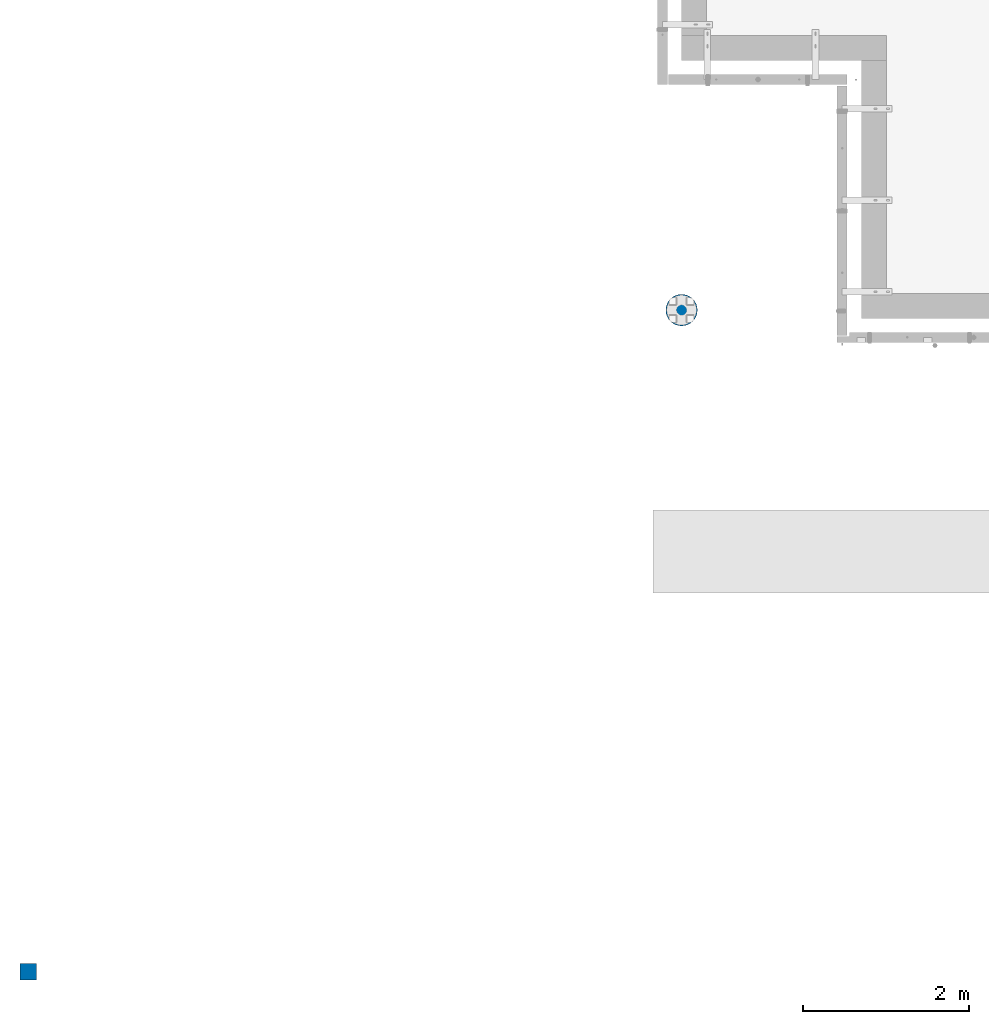
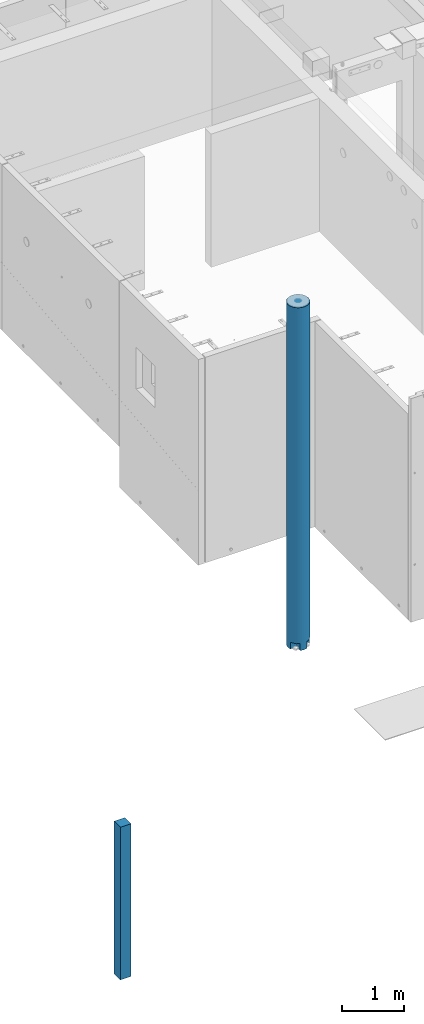
# One storey, part 1 of 264: 2 columns, 2 elements without a shape of their own.
"""IFC2X3 building model written with IfcOpenShell, lengths in millimetres."""

import ifcopenshell
import ifcopenshell.guid

model = None  # the IFC model being written
_history = None  # IfcOwnerHistory: only IFC2X3 demands one
_inside = {}  # id of a spatial element -> (the spatial element, [elements in it])
_under = {}  # id of a project, library or spatial element -> (it, [spatial elements below it])
_declared = {}  # id of a project -> (the project, [libraries it declares])
_typed = {}  # id of a type object -> (the type object, [elements of that type])
_made_of = {}  # id of a material, layer set ... -> (it, [elements and type objects made of it])


def new_model(schema):
    """Start an empty IFC model of exactly this schema.

    Asked for "IFC4X3", IfcOpenShell would pick the latest addendum, in which some entities
    have other attributes; the version numbers below select the first issue.
    IFC2X3 requires an IfcOwnerHistory on every rooted entity: one is made here for all.
    """
    global model, _history
    if schema == "IFC4X3":
        model = ifcopenshell.file(schema_version=(4, 3, 0, 0))
    else:
        model = ifcopenshell.file(schema=schema)
    _inside.clear()
    _under.clear()
    _declared.clear()
    _typed.clear()
    _made_of.clear()
    _history = None
    if model.schema == "IFC2X3":
        org = make("IfcOrganization", Name="unknown")
        user = make(
            "IfcPersonAndOrganization",
            ThePerson=make("IfcPerson", FamilyName="unknown"),
            TheOrganization=org,
        )
        app = make(
            "IfcApplication",
            ApplicationDeveloper=org,
            Version="unknown",
            ApplicationFullName="unknown",
            ApplicationIdentifier="unknown",
        )
        _history = make(
            "IfcOwnerHistory",
            OwningUser=user,
            OwningApplication=app,
            ChangeAction="ADDED",
            CreationDate=0,
        )
    return model


def make(cls, **values):
    """One entity of the class cls with the attributes given. An attribute that is None is left unset."""
    return model.create_entity(
        cls, **{name: value for name, value in values.items() if value is not None}
    )


def rooted(cls, **values):
    """An entity with a GlobalId (a new one), such as an element, a storey or a relation."""
    return make(cls, GlobalId=ifcopenshell.guid.new(), OwnerHistory=_history, **values)


def si_unit(unit_type, name, prefix=None):
    """IfcSIUnit, for example si_unit("LENGTHUNIT", "METRE", prefix="MILLI")."""
    return make("IfcSIUnit", UnitType=unit_type, Prefix=prefix, Name=name)


def assignment(units):
    """IfcUnitAssignment: the units of a project."""
    return None if units is None else make("IfcUnitAssignment", Units=units)


def point(xyz):
    """IfcCartesianPoint."""
    return None if xyz is None else make("IfcCartesianPoint", Coordinates=xyz)


def direction(xyz):
    """IfcDirection."""
    return None if xyz is None else make("IfcDirection", DirectionRatios=xyz)


def frame(location, z_axis=None, x_axis=None):
    """IfcAxis2Placement3D, a coordinate frame: its origin and axes. An axis left out is left unset."""
    return make(
        "IfcAxis2Placement3D",
        Location=point(location),
        Axis=direction(z_axis),
        RefDirection=direction(x_axis),
    )


def origin_with_axes():
    """The frame at (0, 0, 0) with the z axis (0, 0, 1) and the x axis (1, 0, 0) written out."""
    return frame((0.0, 0.0, 0.0), z_axis=(0.0, 0.0, 1.0), x_axis=(1.0, 0.0, 0.0))


def place(relative_to, where):
    """IfcLocalPlacement: puts the frame where relative to a parent placement (None: the world)."""
    return make(
        "IfcLocalPlacement", PlacementRelTo=relative_to, RelativePlacement=where
    )


def context(
    kind, dimensions, precision=None, world=None, true_north=None, identifier=None
):
    """IfcGeometricRepresentationContext, for example the 3D "Model" context."""
    return make(
        "IfcGeometricRepresentationContext",
        ContextIdentifier=identifier,
        ContextType=kind,
        CoordinateSpaceDimension=dimensions,
        Precision=precision,
        WorldCoordinateSystem=world,
        TrueNorth=true_north,
    )


def subcontext(parent, identifier, kind, view, scale=None):
    """IfcGeometricRepresentationSubContext, for example "Body" below "Model"."""
    return make(
        "IfcGeometricRepresentationSubContext",
        ContextIdentifier=identifier,
        ContextType=kind,
        ParentContext=parent,
        TargetScale=scale,
        TargetView=view,
    )


def project(units=None, contexts=None):
    """IfcProject with its units and contexts."""
    return rooted(
        "IfcProject",
        Name="project",
        RepresentationContexts=contexts,
        UnitsInContext=assignment(units),
    )


def spatial(cls, under=None, at=None, **own):
    """A site, building, storey or space (cls), placed at a placement, below another one or the project."""
    s = rooted(cls, ObjectPlacement=at, **own)
    if under is not None:
        _under.setdefault(under.id(), (under, []))[1].append(s)
    return s


def faces_of(points, faces, orient=None, outer=None):
    """IfcFace entities. A face is a list of loops; a loop is a list of indices into points, from 0.

    orient and outer hold one flag for each loop. By default every Orientation is true, the
    first loop of a face is its IfcFaceOuterBound and the others are IfcFaceBound.
    """
    made = []
    for i, loops in enumerate(faces):
        bounds = []
        for j, loop in enumerate(loops):
            is_outer = j == 0 if outer is None else outer[i][j]
            bounds.append(
                make(
                    "IfcFaceOuterBound" if is_outer else "IfcFaceBound",
                    Bound=make("IfcPolyLoop", Polygon=[points[k] for k in loop]),
                    Orientation=True if orient is None else orient[i][j],
                )
            )
        made.append(make("IfcFace", Bounds=bounds))
    return made


def faceted_brep(points, faces, orient=None, outer=None, voids=None):
    """IfcFacetedBrep: a solid bounded by flat faces; with voids (closed shells), ...WithVoids."""
    shared = [point(p) for p in points]
    hull = make("IfcClosedShell", CfsFaces=faces_of(shared, faces, orient, outer))
    if voids is None:
        return make("IfcFacetedBrep", Outer=hull)
    return make(
        "IfcFacetedBrepWithVoids",
        Outer=hull,
        Voids=[
            make(cls, CfsFaces=faces_of(shared, fs, o, b)) for cls, fs, o, b in voids
        ],
    )


def shape(context_of_items, identifier, shape_type, items):
    """IfcShapeRepresentation: the items that make up one representation, for example the "Body"."""
    return make(
        "IfcShapeRepresentation",
        ContextOfItems=context_of_items,
        RepresentationIdentifier=identifier,
        RepresentationType=shape_type,
        Items=items,
    )


def material(Name=None, Category=None):
    """IfcMaterial."""
    return make("IfcMaterial", Name=Name, Category=Category)


def made_of(thing, what):
    """Note that an element or type object is made of a material, layer set ...; save() writes the relation."""
    if what is not None:
        _made_of.setdefault(what.id(), (what, []))[1].append(thing)
    return thing


def type_object(cls, material=None, **own):
    """A type object (cls), such as IfcWallType, which elements share."""
    return made_of(rooted(cls, **own), material)


def element(
    cls,
    number,
    at=None,
    inside=None,
    cuts=None,
    type_object=None,
    material=None,
    context=None,
    identifier="Body",
    shape_type=None,
    held_by="IfcProductDefinitionShape",
    body=None,
    shapes=None,
    **own,
):
    """One element of the class cls, such as IfcWall. Its Tag is "e" and its number.

    at: its placement. inside: the storey or other place that contains it. cuts: it is an
    opening in that element (IfcRelVoidsElement). A single representation is given by context,
    identifier, shape_type and body (its items); several are given by shapes. held_by: the class
    of the entity that holds the representations. save() writes the other relations.
    """
    e = rooted(cls, Tag="e%d" % number, ObjectPlacement=at, **own)
    if body is not None:
        shapes = [shape(context, identifier, shape_type, body)]
    if shapes is not None:
        e.Representation = make(held_by, Representations=shapes)
    if inside is not None:
        _inside.setdefault(inside.id(), (inside, []))[1].append(e)
    if cuts is not None:
        rooted(
            "IfcRelVoidsElement", RelatingBuildingElement=cuts, RelatedOpeningElement=e
        )
    if type_object is not None:
        _typed.setdefault(type_object.id(), (type_object, []))[1].append(e)
    return made_of(e, material)


def aggregate(whole, parts):
    """IfcRelAggregates: a whole, such as a stair, and the parts it consists of."""
    return rooted("IfcRelAggregates", RelatingObject=whole, RelatedObjects=parts)


def save(model, path):
    """Write the relations noted so far, then the file.

    IfcRelAggregates (storeys below a building ...), IfcRelContainedInSpatialStructure (elements
    in a storey), IfcRelDefinesByType, IfcRelAssociatesMaterial and IfcRelDeclares: one each for
    every whole, place, type object, material and project.
    """
    for whole, parts in _under.values():
        aggregate(whole, parts)
    for where, things in _inside.values():
        rooted(
            "IfcRelContainedInSpatialStructure",
            RelatedElements=things,
            RelatingStructure=where,
        )
    for kind, things in _typed.values():
        rooted("IfcRelDefinesByType", RelatedObjects=things, RelatingType=kind)
    for what, things in _made_of.values():
        rooted("IfcRelAssociatesMaterial", RelatedObjects=things, RelatingMaterial=what)
    for by, libraries in _declared.values():
        rooted("IfcRelDeclares", RelatingContext=by, RelatedDefinitions=libraries)
    model.write(path)


model = new_model("IFC2X3")

# Units and contexts
model_context = context("Model", 3, precision=1e-05, world=origin_with_axes())
body_context = subcontext(model_context, "Body", "Model", "MODEL_VIEW")
ifc_project = project(units=[si_unit("LENGTHUNIT", "METRE", prefix="MILLI"), si_unit("AREAUNIT", "SQUARE_METRE"), si_unit("VOLUMEUNIT", "CUBIC_METRE"), si_unit("MASSUNIT", "GRAM", prefix="KILO"), si_unit("TIMEUNIT", "SECOND"), si_unit("PLANEANGLEUNIT", "RADIAN"), si_unit("SOLIDANGLEUNIT", "STERADIAN"), si_unit("THERMODYNAMICTEMPERATUREUNIT", "DEGREE_CELSIUS"), si_unit("LUMINOUSINTENSITYUNIT", "LUMEN")], contexts=[model_context])

# Site, building, storey
site_placement = place(None, origin_with_axes())
site = spatial("IfcSite", under=ifc_project, at=site_placement, CompositionType="ELEMENT")
building_placement = place(site_placement, origin_with_axes())
building = spatial("IfcBuilding", under=site, at=building_placement, CompositionType="ELEMENT")
storey_placement = place(building_placement, origin_with_axes())
storey = spatial("IfcBuildingStorey", under=building, at=storey_placement, Name="K", CompositionType="ELEMENT", Elevation=0.0)

# Assembly, column
assembly_1_placement = place(storey_placement, origin_with_axes())
assembly_1 = element("IfcElementAssembly", 1, at=assembly_1_placement, inside=storey, AssemblyPlace="NOTDEFINED", PredefinedType="REINFORCEMENT_UNIT")
ifc_material_1 = material(Name="CONCRETE/C35/45")
column_type_1 = type_object("IfcColumnType", Name="D380", PredefinedType="NOTDEFINED")
column_1_placement = place(assembly_1_placement, frame((7849.99879520436, 7949.98488883804, 77700.0), z_axis=(0.0, 1.0, 0.0), x_axis=(0.0, 0.0, 1.0)))
column_1 = element("IfcColumn", 2, at=column_1_placement, type_object=column_type_1, material=ifc_material_1, ObjectType="D380", context=body_context, shape_type="Brep", body=[
    faceted_brep([(0.00034332278301008, -178.181865576446, 63.9912653237234), (135.000343322783, -178.181865576445, 63.9912653237234), (135.000343322783, -63.9888557324375, 63.9912653237234), (0.00034332275390625, -63.9888557324375, 63.9912653237234), (135.000343322783, -63.9888557324375, 178.182596517971), (135.000343322783, -175.537111177145, 72.7098521493672), (135.000343322783, -157.979226337484, 105.558344273724), (135.000343322783, -134.350288425444, 134.350288425444), (135.000343322783, -105.558344273724, 157.979226337484), (135.000343322783, -72.7098521493672, 175.537111177145), (0.00034332278301008, -63.9888557324375, 178.182596517971), (0.00034332278301008, -186.349203276615, 37.0671611830658), (0.00034332278301008, -190.0, 0.0), (6735.0, -190.0, 0.0), (6735.0, -186.349203276613, 37.0671611830639), (0.00034332278301008, 178.181865576446, 63.9912653237234), (0.000343322768458165, 64.0010429997965, 63.9912653237234), (135.000343322783, 64.0010429997965, 63.9912653237234), (135.000343322783, 178.181865576445, 63.9912653237234), (135.000343322783, 64.0010429997965, 178.178899550836), (0.00034332278301008, 64.0010429997965, 178.178899550836), (0.00034332278301008, 0.0, 190.0), (0.00034332278301008, -37.0671611830658, 186.349203276615), (6735.0, -37.0671611830639, 186.349203276613), (6735.0, 0.0, 190.0), (0.00034332278301008, 37.0671611830658, 186.349203276615), (6735.0, 37.0671611830639, 186.349203276613), (6735.0, 72.7098521493672, 175.537111177145), (135.000343322783, 72.7098521493672, 175.537111177145), (6735.0, 105.558344273724, 157.979226337484), (135.000343322783, 105.558344273724, 157.979226337484), (6735.0, 134.350288425444, 134.350288425444), (135.000343322783, 134.350288425444, 134.350288425444), (6735.0, 157.979226337484, 105.558344273724), (135.000343322783, 157.979226337484, 105.558344273724), (6735.0, 175.537111177145, 72.7098521493672), (135.000343322783, 175.537111177145, 72.7098521493672), (6735.0, 186.349203276613, 37.0671611830649), (0.00034332278301008, 186.349203276615, 37.0671611830658), (0.00034332278301008, 190.0, 0.0), (6735.0, 190.0, 0.0), (0.00034332278301008, 186.349203276615, -37.0671611830658), (6735.0, 186.349203276613, -37.0671611830639), (6735.0, 105.558344273724, -157.979226337484), (6735.0, 72.7098521493672, -175.537111177145), (135.000343322783, 72.7098521493672, -175.537111177145), (135.000343322783, 105.558344273724, -157.979226337484), (6735.0, 134.350288425444, -134.350288425444), (135.000343322783, 134.350288425444, -134.350288425444), (6735.0, 157.979226337484, -105.558344273724), (135.000343322783, 157.979226337484, -105.558344273724), (6735.0, 175.537111177145, -72.7098521493672), (135.000343322783, 175.537111177145, -72.7098521493672), (135.000343322783, 178.179630492362, -63.9986334085106), (0.00034332278301008, 178.179630492362, -63.9986334085106), (0.000343322768458165, 64.0010429997965, -63.9986334085106), (135.000343322783, 64.0010429997965, -63.9986334085106), (135.000343322783, 64.0010429997965, -178.178899550836), (0.00034332278301008, 64.0010429997965, -178.178899550836), (6735.0, 37.0671611830649, -186.349203276613), (0.00034332278301008, 37.0671611830658, -186.349203276615), (0.00034332278301008, 0.0, -190.0), (6735.0, 0.0, -190.0), (0.00034332278301008, -37.0671611830658, -186.349203276615), (6735.0, -37.0671611830639, -186.349203276613), (6735.0, -157.979226337484, -105.558344273724), (6735.0, -175.537111177145, -72.7098521493672), (135.000343322783, -175.537111177145, -72.7098521493672), (135.000343322783, -157.979226337484, -105.558344273724), (6735.0, -134.350288425444, -134.350288425444), (135.000343322783, -134.350288425444, -134.350288425444), (6735.0, -105.558344273724, -157.979226337484), (135.000343322783, -105.558344273724, -157.979226337484), (6735.0, -72.7098521493672, -175.537111177145), (135.000343322783, -72.7098521493672, -175.537111177145), (135.000343322783, -63.9888557324375, -178.182596517971), (0.00034332278301008, -63.9888557324375, -178.182596517971), (0.000343322768458165, -63.9888557324375, -63.9986334085106), (135.000343322783, -63.9888557324375, -63.9986334085106), (135.000343322783, -178.179630492361, -63.9986334085106), (0.00034332278301008, -178.179630492362, -63.9986334085106), (6735.0, -186.349203276613, -37.0671611830649), (0.00034332278301008, -186.349203276615, -37.0671611830658), (6735.0, -72.7098521493672, 175.537111177145), (6735.0, -105.558344273724, 157.979226337484), (6735.0, -134.350288425444, 134.350288425444), (6735.0, -157.979226337484, 105.558344273724), (6735.0, -175.537111177145, 72.7098521493672)], [[[0, 1, 2, 3]], [[4, 2, 1, 5, 6, 7, 8, 9]], [[10, 3, 2, 4]], [[11, 12, 13, 14]], [[15, 16, 17, 18]], [[19, 17, 16, 20]], [[21, 22, 23, 24]], [[25, 21, 24, 26]], [[20, 25, 26, 27, 28, 19]], [[27, 29, 30, 28]], [[29, 31, 32, 30]], [[31, 33, 34, 32]], [[33, 35, 36, 34]], [[18, 17, 19, 28, 30, 32, 34, 36]], [[35, 37, 38, 15, 18, 36]], [[39, 38, 37, 40]], [[41, 39, 40, 42]], [[43, 44, 45, 46]], [[47, 43, 46, 48]], [[49, 47, 48, 50]], [[51, 49, 50, 52]], [[41, 42, 51, 52, 53, 54]], [[55, 56, 57, 58]], [[53, 56, 55, 54]], [[52, 50, 48, 46, 45, 57, 56, 53]], [[44, 59, 60, 58, 57, 45]], [[61, 60, 59, 62]], [[63, 61, 62, 64]], [[65, 66, 67, 68]], [[69, 65, 68, 70]], [[71, 69, 70, 72]], [[73, 71, 72, 74]], [[63, 64, 73, 74, 75, 76]], [[77, 78, 79, 80]], [[76, 75, 78, 77]], [[74, 72, 70, 68, 67, 79, 78, 75]], [[66, 81, 82, 80, 79, 67]], [[12, 82, 81, 13]], [[66, 65, 69, 71, 73, 64, 62, 59, 44, 43, 47, 49, 51, 42, 40, 37, 35, 33, 31, 29, 27, 26, 24, 23, 83, 84, 85, 86, 87, 14, 13, 81]], [[84, 83, 9, 8]], [[85, 84, 8, 7]], [[86, 85, 7, 6]], [[87, 86, 6, 5]], [[0, 11, 14, 87, 5, 1]], [[22, 21, 25, 20, 16, 15, 38, 39, 41, 54, 55, 58, 60, 61, 63, 76, 77, 80, 82, 12, 11, 0, 3, 10]], [[83, 23, 22, 10, 4, 9]]]),
])
aggregate(assembly_1, [column_1])

assembly_2_placement = place(storey_placement, origin_with_axes())
assembly_2 = element("IfcElementAssembly", 3, at=assembly_2_placement, inside=storey, AssemblyPlace="NOTDEFINED", PredefinedType="REINFORCEMENT_UNIT")
ifc_material_2 = material(Name="CONCRETE/Concrete_Undefined")
column_type_2 = type_object("IfcColumnType", PredefinedType="NOTDEFINED")
column_2_placement = place(assembly_2_placement, frame((0.0, 0.0, 78760.0), z_axis=(0.0, 1.0, 0.0), x_axis=(0.0, 0.0, 1.0)))
column_2 = element("IfcColumn", 4, at=column_2_placement, type_object=column_type_2, material=ifc_material_2, context=body_context, shape_type="Brep", body=[
    faceted_brep([(0.0, 100.0, -100.0), (0.0, 100.0, 100.0), (3000.0, 100.0, 100.0), (3000.0, 100.0, -100.0), (0.0, -100.0, 100.0), (3000.0, -100.0, 100.0), (0.0, -100.0, -100.0), (3000.0, -100.0, -100.0)], [[[0, 1, 2, 3]], [[1, 4, 5, 2]], [[4, 6, 7, 5]], [[6, 0, 3, 7]], [[5, 7, 3, 2]], [[6, 4, 1, 0]]]),
])
aggregate(assembly_2, [column_2])

save(model, "model.ifc")
